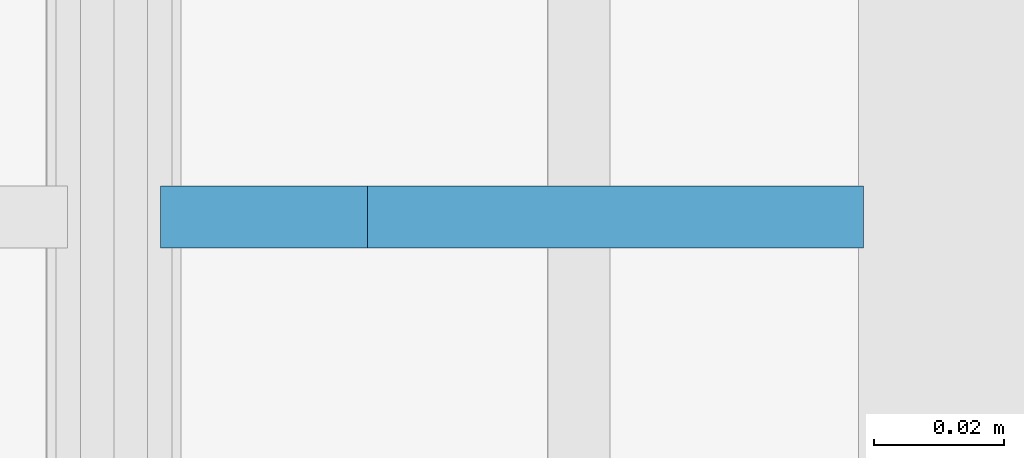
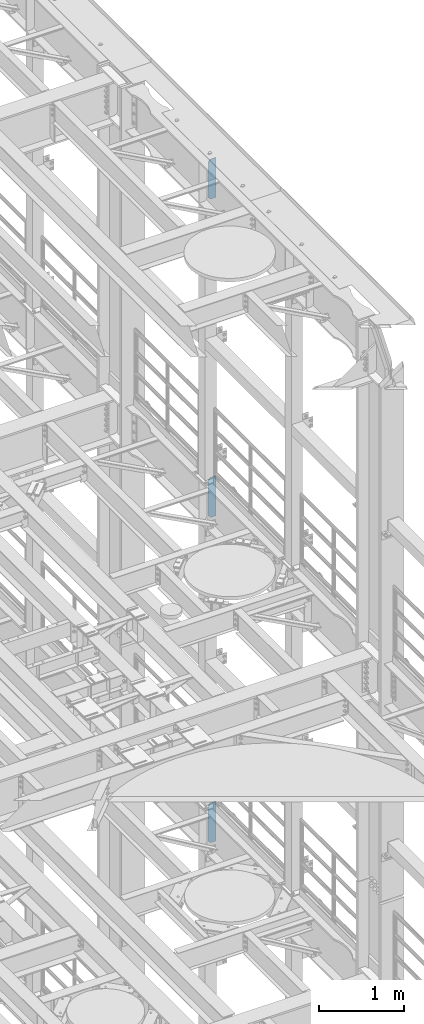
# One storey, part 1683 of 1876: 3 plates, 3 elements without a shape of their own.
"""IFC2X3 building model written with IfcOpenShell, lengths in millimetres."""

import ifcopenshell
import ifcopenshell.guid

model = None  # the IFC model being written
_history = None  # IfcOwnerHistory: only IFC2X3 demands one
_inside = {}  # id of a spatial element -> (the spatial element, [elements in it])
_under = {}  # id of a project, library or spatial element -> (it, [spatial elements below it])
_declared = {}  # id of a project -> (the project, [libraries it declares])
_typed = {}  # id of a type object -> (the type object, [elements of that type])
_made_of = {}  # id of a material, layer set ... -> (it, [elements and type objects made of it])


def new_model(schema):
    """Start an empty IFC model of exactly this schema.

    Asked for "IFC4X3", IfcOpenShell would pick the latest addendum, in which some entities
    have other attributes; the version numbers below select the first issue.
    IFC2X3 requires an IfcOwnerHistory on every rooted entity: one is made here for all.
    """
    global model, _history
    if schema == "IFC4X3":
        model = ifcopenshell.file(schema_version=(4, 3, 0, 0))
    else:
        model = ifcopenshell.file(schema=schema)
    _inside.clear()
    _under.clear()
    _declared.clear()
    _typed.clear()
    _made_of.clear()
    _history = None
    if model.schema == "IFC2X3":
        org = make("IfcOrganization", Name="unknown")
        user = make(
            "IfcPersonAndOrganization",
            ThePerson=make("IfcPerson", FamilyName="unknown"),
            TheOrganization=org,
        )
        app = make(
            "IfcApplication",
            ApplicationDeveloper=org,
            Version="unknown",
            ApplicationFullName="unknown",
            ApplicationIdentifier="unknown",
        )
        _history = make(
            "IfcOwnerHistory",
            OwningUser=user,
            OwningApplication=app,
            ChangeAction="ADDED",
            CreationDate=0,
        )
    return model


def make(cls, **values):
    """One entity of the class cls with the attributes given. An attribute that is None is left unset."""
    return model.create_entity(
        cls, **{name: value for name, value in values.items() if value is not None}
    )


def rooted(cls, **values):
    """An entity with a GlobalId (a new one), such as an element, a storey or a relation."""
    return make(cls, GlobalId=ifcopenshell.guid.new(), OwnerHistory=_history, **values)


def si_unit(unit_type, name, prefix=None):
    """IfcSIUnit, for example si_unit("LENGTHUNIT", "METRE", prefix="MILLI")."""
    return make("IfcSIUnit", UnitType=unit_type, Prefix=prefix, Name=name)


def assignment(units):
    """IfcUnitAssignment: the units of a project."""
    return None if units is None else make("IfcUnitAssignment", Units=units)


def point(xyz):
    """IfcCartesianPoint."""
    return None if xyz is None else make("IfcCartesianPoint", Coordinates=xyz)


def direction(xyz):
    """IfcDirection."""
    return None if xyz is None else make("IfcDirection", DirectionRatios=xyz)


def frame(location, z_axis=None, x_axis=None):
    """IfcAxis2Placement3D, a coordinate frame: its origin and axes. An axis left out is left unset."""
    return make(
        "IfcAxis2Placement3D",
        Location=point(location),
        Axis=direction(z_axis),
        RefDirection=direction(x_axis),
    )


def origin_with_axes():
    """The frame at (0, 0, 0) with the z axis (0, 0, 1) and the x axis (1, 0, 0) written out."""
    return frame((0.0, 0.0, 0.0), z_axis=(0.0, 0.0, 1.0), x_axis=(1.0, 0.0, 0.0))


def place(relative_to, where):
    """IfcLocalPlacement: puts the frame where relative to a parent placement (None: the world)."""
    return make(
        "IfcLocalPlacement", PlacementRelTo=relative_to, RelativePlacement=where
    )


def context(
    kind, dimensions, precision=None, world=None, true_north=None, identifier=None
):
    """IfcGeometricRepresentationContext, for example the 3D "Model" context."""
    return make(
        "IfcGeometricRepresentationContext",
        ContextIdentifier=identifier,
        ContextType=kind,
        CoordinateSpaceDimension=dimensions,
        Precision=precision,
        WorldCoordinateSystem=world,
        TrueNorth=true_north,
    )


def subcontext(parent, identifier, kind, view, scale=None):
    """IfcGeometricRepresentationSubContext, for example "Body" below "Model"."""
    return make(
        "IfcGeometricRepresentationSubContext",
        ContextIdentifier=identifier,
        ContextType=kind,
        ParentContext=parent,
        TargetScale=scale,
        TargetView=view,
    )


def project(units=None, contexts=None):
    """IfcProject with its units and contexts."""
    return rooted(
        "IfcProject",
        Name="project",
        RepresentationContexts=contexts,
        UnitsInContext=assignment(units),
    )


def spatial(cls, under=None, at=None, **own):
    """A site, building, storey or space (cls), placed at a placement, below another one or the project."""
    s = rooted(cls, ObjectPlacement=at, **own)
    if under is not None:
        _under.setdefault(under.id(), (under, []))[1].append(s)
    return s


def faces_of(points, faces, orient=None, outer=None):
    """IfcFace entities. A face is a list of loops; a loop is a list of indices into points, from 0.

    orient and outer hold one flag for each loop. By default every Orientation is true, the
    first loop of a face is its IfcFaceOuterBound and the others are IfcFaceBound.
    """
    made = []
    for i, loops in enumerate(faces):
        bounds = []
        for j, loop in enumerate(loops):
            is_outer = j == 0 if outer is None else outer[i][j]
            bounds.append(
                make(
                    "IfcFaceOuterBound" if is_outer else "IfcFaceBound",
                    Bound=make("IfcPolyLoop", Polygon=[points[k] for k in loop]),
                    Orientation=True if orient is None else orient[i][j],
                )
            )
        made.append(make("IfcFace", Bounds=bounds))
    return made


def faceted_brep(points, faces, orient=None, outer=None, voids=None):
    """IfcFacetedBrep: a solid bounded by flat faces; with voids (closed shells), ...WithVoids."""
    shared = [point(p) for p in points]
    hull = make("IfcClosedShell", CfsFaces=faces_of(shared, faces, orient, outer))
    if voids is None:
        return make("IfcFacetedBrep", Outer=hull)
    return make(
        "IfcFacetedBrepWithVoids",
        Outer=hull,
        Voids=[
            make(cls, CfsFaces=faces_of(shared, fs, o, b)) for cls, fs, o, b in voids
        ],
    )


def shape(context_of_items, identifier, shape_type, items):
    """IfcShapeRepresentation: the items that make up one representation, for example the "Body"."""
    return make(
        "IfcShapeRepresentation",
        ContextOfItems=context_of_items,
        RepresentationIdentifier=identifier,
        RepresentationType=shape_type,
        Items=items,
    )


def material(Name=None, Category=None):
    """IfcMaterial."""
    return make("IfcMaterial", Name=Name, Category=Category)


def made_of(thing, what):
    """Note that an element or type object is made of a material, layer set ...; save() writes the relation."""
    if what is not None:
        _made_of.setdefault(what.id(), (what, []))[1].append(thing)
    return thing


def type_object(cls, material=None, **own):
    """A type object (cls), such as IfcWallType, which elements share."""
    return made_of(rooted(cls, **own), material)


def element(
    cls,
    number,
    at=None,
    inside=None,
    cuts=None,
    type_object=None,
    material=None,
    context=None,
    identifier="Body",
    shape_type=None,
    held_by="IfcProductDefinitionShape",
    body=None,
    shapes=None,
    **own,
):
    """One element of the class cls, such as IfcWall. Its Tag is "e" and its number.

    at: its placement. inside: the storey or other place that contains it. cuts: it is an
    opening in that element (IfcRelVoidsElement). A single representation is given by context,
    identifier, shape_type and body (its items); several are given by shapes. held_by: the class
    of the entity that holds the representations. save() writes the other relations.
    """
    e = rooted(cls, Tag="e%d" % number, ObjectPlacement=at, **own)
    if body is not None:
        shapes = [shape(context, identifier, shape_type, body)]
    if shapes is not None:
        e.Representation = make(held_by, Representations=shapes)
    if inside is not None:
        _inside.setdefault(inside.id(), (inside, []))[1].append(e)
    if cuts is not None:
        rooted(
            "IfcRelVoidsElement", RelatingBuildingElement=cuts, RelatedOpeningElement=e
        )
    if type_object is not None:
        _typed.setdefault(type_object.id(), (type_object, []))[1].append(e)
    return made_of(e, material)


def aggregate(whole, parts):
    """IfcRelAggregates: a whole, such as a stair, and the parts it consists of."""
    return rooted("IfcRelAggregates", RelatingObject=whole, RelatedObjects=parts)


def save(model, path):
    """Write the relations noted so far, then the file.

    IfcRelAggregates (storeys below a building ...), IfcRelContainedInSpatialStructure (elements
    in a storey), IfcRelDefinesByType, IfcRelAssociatesMaterial and IfcRelDeclares: one each for
    every whole, place, type object, material and project.
    """
    for whole, parts in _under.values():
        aggregate(whole, parts)
    for where, things in _inside.values():
        rooted(
            "IfcRelContainedInSpatialStructure",
            RelatedElements=things,
            RelatingStructure=where,
        )
    for kind, things in _typed.values():
        rooted("IfcRelDefinesByType", RelatedObjects=things, RelatingType=kind)
    for what, things in _made_of.values():
        rooted("IfcRelAssociatesMaterial", RelatedObjects=things, RelatingMaterial=what)
    for by, libraries in _declared.values():
        rooted("IfcRelDeclares", RelatingContext=by, RelatedDefinitions=libraries)
    model.write(path)


model = new_model("IFC2X3")

# Units and contexts
model_context = context("Model", 3, precision=1e-05, world=origin_with_axes())
body_context = subcontext(model_context, "Body", "Model", "MODEL_VIEW")
ifc_project = project(units=[si_unit("LENGTHUNIT", "METRE", prefix="MILLI"), si_unit("AREAUNIT", "SQUARE_METRE"), si_unit("VOLUMEUNIT", "CUBIC_METRE"), si_unit("MASSUNIT", "GRAM", prefix="KILO"), si_unit("TIMEUNIT", "SECOND"), si_unit("PLANEANGLEUNIT", "RADIAN"), si_unit("SOLIDANGLEUNIT", "STERADIAN"), si_unit("THERMODYNAMICTEMPERATUREUNIT", "DEGREE_CELSIUS"), si_unit("LUMINOUSINTENSITYUNIT", "LUMEN")], contexts=[model_context])

# Site, building, storey
site_placement = place(None, origin_with_axes())
site = spatial("IfcSite", under=ifc_project, at=site_placement, CompositionType="ELEMENT")
building_placement = place(site_placement, origin_with_axes())
building = spatial("IfcBuilding", under=site, at=building_placement, Name="Undefined", CompositionType="ELEMENT")
storey_placement = place(building_placement, origin_with_axes())
storey = spatial("IfcBuildingStorey", under=building, at=storey_placement, Name="Undefined", CompositionType="ELEMENT", Elevation=0.0)

# Assembly, plate
assembly_1_placement = place(storey_placement, origin_with_axes())
assembly_1 = element("IfcElementAssembly", 1, at=assembly_1_placement, inside=storey, Name="BEAM", AssemblyPlace="NOTDEFINED", PredefinedType="RIGID_FRAME")
ifc_material = material(Name="STEEL/A36")
plate_type = type_object("IfcPlateType", PredefinedType="NOTDEFINED")
plate_1_placement = place(assembly_1_placement, frame((7735.09375, 5588.0, 21958.3), z_axis=(0.0, 0.0, 1.0), x_axis=(-1.0, 0.0, 0.0)))
plate_1 = element("IfcPlate", 2, at=plate_1_placement, type_object=plate_type, material=ifc_material, Name="PLATE", context=body_context, shape_type="Brep", body=[
    faceted_brep([(0.0, -4.76249999999982, 0.0), (0.0, -4.76249999999982, 571.5), (0.0, 4.76249999999982, 571.5), (0.0, 4.76249999999982, 0.0), (76.1999969482422, -4.76249999999982, 571.5), (76.1999969482422, 4.76249999999982, 571.5), (107.949996948242, -4.76249999999982, 539.75), (107.949996948242, 4.76249999999982, 539.75), (107.949996948242, -4.76249999999982, 31.75), (107.949996948242, 4.76249999999982, 31.75), (76.1999969482422, -4.76250000000073, 0.0), (76.1999969482422, 4.76250000000073, 0.0)], [[[0, 1, 2, 3]], [[1, 4, 5, 2]], [[4, 6, 7, 5]], [[6, 8, 9, 7]], [[8, 10, 11, 9]], [[10, 0, 3, 11]], [[5, 7, 9, 11, 3, 2]], [[10, 8, 6, 4, 1, 0]]]),
])
aggregate(assembly_1, [plate_1])

assembly_2_placement = place(storey_placement, origin_with_axes())
assembly_2 = element("IfcElementAssembly", 3, at=assembly_2_placement, inside=storey, Name="BEAM", AssemblyPlace="NOTDEFINED", PredefinedType="RIGID_FRAME")
plate_2_placement = place(assembly_2_placement, frame((7735.09375, 5588.0, 17386.3), z_axis=(0.0, 0.0, 1.0), x_axis=(-1.0, 0.0, 0.0)))
plate_2 = element("IfcPlate", 4, at=plate_2_placement, type_object=plate_type, material=ifc_material, Name="PLATE", context=body_context, shape_type="Brep", body=[
    faceted_brep([(0.0, -4.76249999999982, 0.0), (0.0, -4.76249999999982, 571.5), (0.0, 4.76249999999982, 571.5), (0.0, 4.76249999999982, 0.0), (76.1999969482422, -4.76249999999982, 571.5), (76.1999969482422, 4.76249999999982, 571.5), (107.949996948242, -4.76249999999982, 539.75), (107.949996948242, 4.76249999999982, 539.75), (107.949996948242, -4.76249999999982, 31.75), (107.949996948242, 4.76249999999982, 31.75), (76.1999969482422, -4.76250000000073, 0.0), (76.1999969482422, 4.76250000000073, 0.0)], [[[0, 1, 2, 3]], [[1, 4, 5, 2]], [[4, 6, 7, 5]], [[6, 8, 9, 7]], [[8, 10, 11, 9]], [[10, 0, 3, 11]], [[5, 7, 9, 11, 3, 2]], [[10, 8, 6, 4, 1, 0]]]),
])
aggregate(assembly_2, [plate_2])

assembly_3_placement = place(storey_placement, origin_with_axes())
assembly_3 = element("IfcElementAssembly", 5, at=assembly_3_placement, inside=storey, Name="BEAM", AssemblyPlace="NOTDEFINED", PredefinedType="RIGID_FRAME")
plate_3_placement = place(assembly_3_placement, frame((7735.09375, 5588.0, 12712.7), z_axis=(0.0, 0.0, 1.0), x_axis=(-1.0, 0.0, 0.0)))
plate_3 = element("IfcPlate", 6, at=plate_3_placement, type_object=plate_type, material=ifc_material, Name="PLATE", context=body_context, shape_type="Brep", body=[
    faceted_brep([(0.0, -4.76249999999982, 0.0), (0.0, -4.76249999999982, 571.5), (0.0, 4.76249999999982, 571.5), (0.0, 4.76249999999982, 0.0), (76.1999969482422, -4.76249999999982, 571.5), (76.1999969482422, 4.76249999999982, 571.5), (107.949996948242, -4.76249999999982, 539.75), (107.949996948242, 4.76249999999982, 539.75), (107.949996948242, -4.76249999999982, 31.75), (107.949996948242, 4.76249999999982, 31.75), (76.1999969482422, -4.76250000000073, 0.0), (76.1999969482422, 4.76250000000073, 0.0)], [[[0, 1, 2, 3]], [[1, 4, 5, 2]], [[4, 6, 7, 5]], [[6, 8, 9, 7]], [[8, 10, 11, 9]], [[10, 0, 3, 11]], [[5, 7, 9, 11, 3, 2]], [[10, 8, 6, 4, 1, 0]]]),
])
aggregate(assembly_3, [plate_3])

save(model, "model.ifc")
